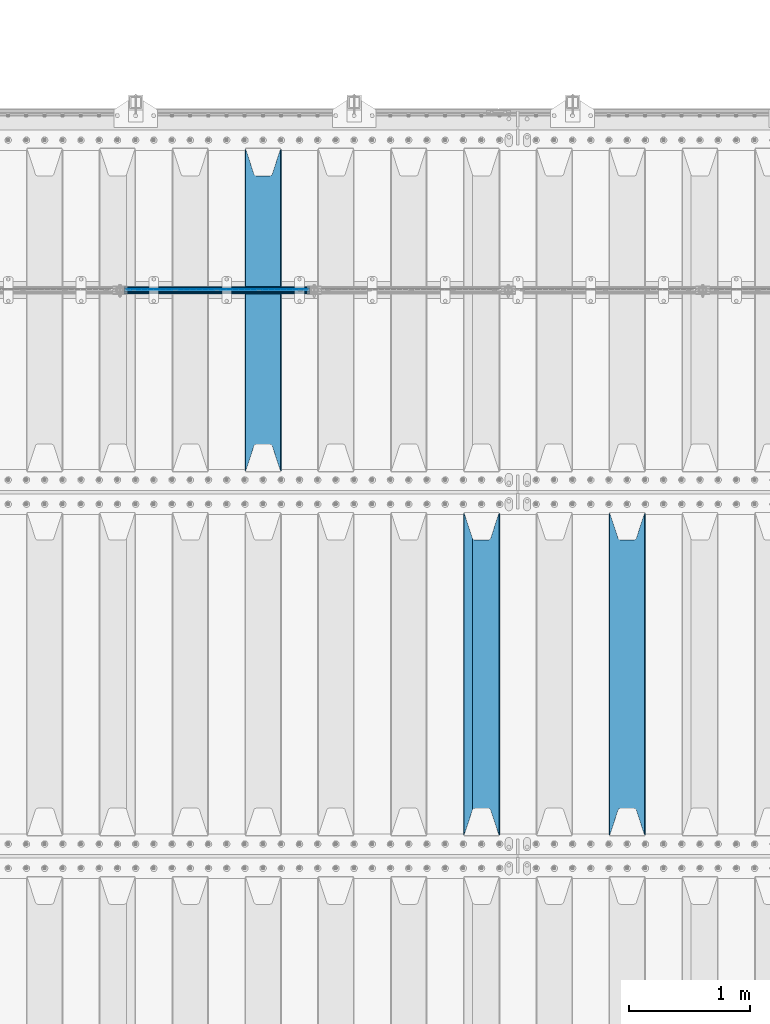
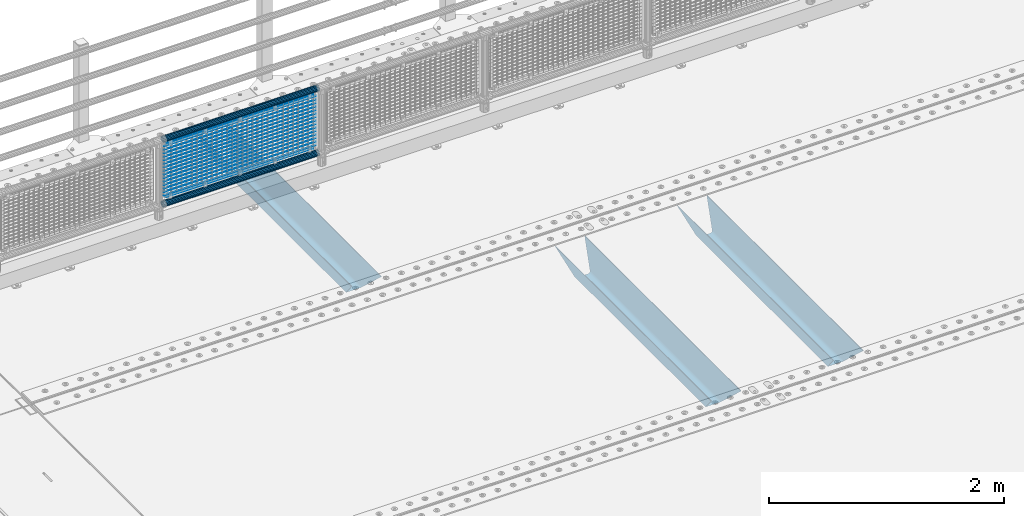
# One storey, part 117 of 257: 22 beams.
"""IFC2X3 building model written with IfcOpenShell, lengths in millimetres."""

from ifc_helpers import new_model, si_unit, frame, origin_with_axes, place, context, subcontext, project, spatial, faceted_brep, material, type_object, element, save


model = new_model("IFC2X3")

# Units and contexts
model_context = context("Model", 3, precision=1e-05, world=origin_with_axes())
body_context = subcontext(model_context, "Body", "Model", "MODEL_VIEW")
ifc_project = project(units=[si_unit("LENGTHUNIT", "METRE", prefix="MILLI"), si_unit("AREAUNIT", "SQUARE_METRE"), si_unit("VOLUMEUNIT", "CUBIC_METRE"), si_unit("MASSUNIT", "GRAM", prefix="KILO"), si_unit("TIMEUNIT", "SECOND"), si_unit("PLANEANGLEUNIT", "RADIAN"), si_unit("SOLIDANGLEUNIT", "STERADIAN"), si_unit("THERMODYNAMICTEMPERATUREUNIT", "DEGREE_CELSIUS"), si_unit("LUMINOUSINTENSITYUNIT", "LUMEN")], contexts=[model_context])

# Site, building, storey
site_placement = place(None, origin_with_axes())
site = spatial("IfcSite", under=ifc_project, at=site_placement, CompositionType="ELEMENT")
building_placement = place(site_placement, origin_with_axes())
building = spatial("IfcBuilding", under=site, at=building_placement, Name="Standard", CompositionType="ELEMENT")
storey_placement = place(building_placement, origin_with_axes())
storey = spatial("IfcBuildingStorey", under=building, at=storey_placement, Name="Undefined", CompositionType="ELEMENT", Elevation=0.0)

# Beams
ifc_material_1 = material(Name="STEEL/S355N")
beam_type_1 = type_object("IfcBeamType", PredefinedType="NOTDEFINED")
beam_1_placement = place(storey_placement, frame((48850.0, 6175.0, -115.0), z_axis=(0.0, 0.0, 1.0), x_axis=(0.0, 1.0, 0.0)))
element("IfcBeam", 1, at=beam_1_placement, inside=storey, type_object=beam_type_1, material=ifc_material_1, context=body_context, shape_type="Brep", body=[
    faceted_brep([(0.0, 150.0, 115.0), (0.0, 143.690000000002, 115.0), (2650.00000000297, 143.690000000002, 115.0), (2650.00000000297, 150.0, 115.0), (2650.00000000297, 142.059565218406, 110.0000000031), (2650.00000000297, 148.369565218403, 110.0000000031), (2441.90079219208, -80.1103600731149, -98.0992078077845), (2437.7588105432, -77.5672621345584, -102.241189456673), (2434.06523489746, -74.4080125315522, -105.934765102404), (2430.91086095089, -70.7102721255724, -109.089139048974), (2428.37322971128, -66.5649389910031, -111.626770288588), (2426.51472138055, -62.0739139532889, -113.485278619323), (2425.38102192091, -57.3475956567636, -114.618978078955), (2424.99999999987, -52.5021667386536, -115.0), (2424.99999999987, 52.5021667386536, -115.0), (2425.38102192091, 57.3475956567636, -114.618978078955), (2426.51472138055, 62.0739139532889, -113.485278619323), (2428.37322971128, 66.5649389910031, -111.626770288588), (2430.91086095089, 70.7102721255724, -109.089139048974), (2434.06523489746, 74.4080125315522, -105.934765102404), (2437.7588105432, 77.5672621345584, -102.241189456673), (2441.90079219208, 80.1103600731149, -98.0992078077846), (2446.38936140511, 81.9747917625791, -93.6106385947584), (2448.24948500409, 76.2713538057287, -91.7505149957729), (2444.62967112262, 74.76777986261, -95.3703288772456), (2441.28936334126, 72.7168944282894, -98.710636658607), (2438.31067330438, 70.1691124903809, -101.689326695487), (2435.76682334747, 67.1870637758839, -104.233176652398), (2433.72034654133, 63.8440531834931, -106.279653458539), (2432.22154950041, 60.2222587982324, -107.778450499454), (2431.30727574265, 56.4107117849126, -108.692724257221), (2430.99999999987, 52.5031078186876, -109.0), (2430.99999999987, -52.5031078186876, -109.0), (2431.30727574265, -56.4107117849126, -108.692724257221), (2432.22154950041, -60.2222587982324, -107.778450499454), (2433.72034654133, -63.8440531834931, -106.279653458539), (2435.76682334747, -67.1870637758839, -104.233176652398), (2438.31067330438, -70.1691124903809, -101.689326695487), (2441.28936334126, -72.7168944282894, -98.7106366586071), (2444.62967112262, -74.76777986261, -95.3703288772457), (2448.24948500409, -76.2713538057287, -91.7505149957729), (2650.00000000297, -142.059565218406, 110.0000000031), (2650.00000000297, -148.369565218403, 110.0000000031), (2446.38936140511, -81.9747917625791, -93.6106385947584), (2650.00000000297, -143.690000000002, 115.0), (2650.00000000297, -150.0, 115.0), (0.0, -143.690000000002, 115.0), (0.0, -150.0, 115.0), (0.0, -148.369565218258, 110.000000002662), (203.61063859742, -81.9747917625791, -93.6106385947584), (208.099207810447, -80.1103600731149, -98.0992078077845), (212.241189459335, -77.5672621345584, -102.241189456673), (215.934765105066, -74.4080125315522, -105.934765102404), (219.089139051636, -70.7102721255724, -109.089139048974), (221.626770291251, -66.5649389910031, -111.626770288588), (223.485278621985, -62.0739139532889, -113.485278619323), (224.618978081617, -57.3475956567636, -114.618978078955), (225.000000002662, -52.5021667386536, -115.0), (225.000000002662, 52.5021667386536, -115.0), (224.618978081617, 57.3475956567636, -114.618978078955), (223.485278621985, 62.0739139532889, -113.485278619323), (221.626770291251, 66.5649389910031, -111.626770288588), (219.089139051636, 70.7102721255724, -109.089139048974), (215.934765105066, 74.4080125315522, -105.934765102404), (212.241189459335, 77.5672621345584, -102.241189456673), (208.099207810447, 80.1103600731149, -98.0992078077846), (203.61063859742, 81.9747917625791, -93.6106385947584), (0.0, 148.369565218258, 110.000000002662), (0.0, 142.05956521826, 110.000000002662), (201.750514998435, 76.2713538057287, -91.7505149957729), (205.370328879908, 74.76777986261, -95.3703288772456), (208.710636661269, 72.7168944282894, -98.710636658607), (211.689326698149, 70.1691124903809, -101.689326695487), (214.233176655061, 67.1870637758839, -104.233176652398), (216.279653461201, 63.8440531834931, -106.279653458539), (217.778450502116, 60.2222587982324, -107.778450499454), (218.692724259884, 56.4107117849126, -108.692724257221), (219.000000002662, 52.5031078186876, -109.0), (219.000000002662, -52.5031078186876, -109.0), (218.692724259884, -56.4107117849126, -108.692724257221), (217.778450502116, -60.2222587982324, -107.778450499454), (216.279653461201, -63.8440531834931, -106.279653458539), (214.233176655061, -67.1870637758839, -104.233176652398), (211.689326698149, -70.1691124903809, -101.689326695487), (208.710636661269, -72.7168944282894, -98.7106366586071), (205.370328879908, -74.76777986261, -95.3703288772457), (201.750514998435, -76.2713538057287, -91.7505149957729), (0.0, -142.05956521826, 110.000000002662)], [[[0, 1, 2, 3]], [[3, 2, 4, 5]], [[6, 7, 8, 9, 10, 11, 12, 13, 14, 15, 16, 17, 18, 19, 20, 21, 22, 5, 4, 23, 24, 25, 26, 27, 28, 29, 30, 31, 32, 33, 34, 35, 36, 37, 38, 39, 40, 41, 42, 43]], [[44, 45, 42, 41]], [[46, 47, 45, 44]], [[43, 42, 45, 47, 48, 49]], [[6, 43, 49, 50]], [[7, 6, 50, 51]], [[8, 7, 51, 52]], [[9, 8, 52, 53]], [[10, 9, 53, 54]], [[11, 10, 54, 55]], [[12, 11, 55, 56]], [[13, 12, 56, 57]], [[14, 13, 57, 58]], [[15, 14, 58, 59]], [[16, 15, 59, 60]], [[17, 16, 60, 61]], [[18, 17, 61, 62]], [[19, 18, 62, 63]], [[20, 19, 63, 64]], [[21, 20, 64, 65]], [[22, 21, 65, 66]], [[0, 3, 5, 22, 66, 67]], [[1, 0, 67, 68]], [[23, 4, 2, 1, 68, 69]], [[24, 23, 69, 70]], [[25, 24, 70, 71]], [[26, 25, 71, 72]], [[27, 26, 72, 73]], [[28, 27, 73, 74]], [[29, 28, 74, 75]], [[30, 29, 75, 76]], [[31, 30, 76, 77]], [[32, 31, 77, 78]], [[33, 32, 78, 79]], [[34, 33, 79, 80]], [[35, 34, 80, 81]], [[36, 35, 81, 82]], [[37, 36, 82, 83]], [[38, 37, 83, 84]], [[39, 38, 84, 85]], [[40, 39, 85, 86]], [[46, 44, 41, 40, 86, 87]], [[47, 46, 87, 48]], [[86, 85, 84, 83, 82, 81, 80, 79, 78, 77, 76, 75, 74, 73, 72, 71, 70, 69, 68, 67, 66, 65, 64, 63, 62, 61, 60, 59, 58, 57, 56, 55, 54, 53, 52, 51, 50, 49, 48, 87]]]),
])
beam_2_placement = place(storey_placement, frame((47650.0, 6175.0, -115.0), z_axis=(0.0, 0.0, 1.0), x_axis=(0.0, 1.0, 0.0)))
element("IfcBeam", 2, at=beam_2_placement, inside=storey, type_object=beam_type_1, material=ifc_material_1, context=body_context, shape_type="Brep", body=[
    faceted_brep([(0.0, 150.0, 115.0), (0.0, 143.690000000002, 115.0), (2650.00000000297, 143.690000000002, 115.0), (2650.00000000297, 150.0, 115.0), (2650.00000000297, 142.059565218406, 110.0000000031), (2650.00000000297, 148.369565218403, 110.0000000031), (2441.90079219208, -80.1103600731149, -98.0992078077845), (2437.7588105432, -77.5672621345584, -102.241189456673), (2434.06523489746, -74.4080125315522, -105.934765102404), (2430.91086095089, -70.7102721255724, -109.089139048974), (2428.37322971128, -66.5649389910031, -111.626770288588), (2426.51472138055, -62.0739139532889, -113.485278619323), (2425.38102192091, -57.3475956567636, -114.618978078955), (2424.99999999987, -52.5021667386536, -115.0), (2424.99999999987, 52.5021667386536, -115.0), (2425.38102192091, 57.3475956567636, -114.618978078955), (2426.51472138055, 62.0739139532889, -113.485278619323), (2428.37322971128, 66.5649389910031, -111.626770288588), (2430.91086095089, 70.7102721255724, -109.089139048974), (2434.06523489746, 74.4080125315522, -105.934765102404), (2437.7588105432, 77.5672621345584, -102.241189456673), (2441.90079219208, 80.1103600731149, -98.0992078077846), (2446.38936140511, 81.9747917625791, -93.6106385947584), (2448.24948500409, 76.2713538057287, -91.7505149957729), (2444.62967112262, 74.76777986261, -95.3703288772456), (2441.28936334126, 72.7168944282894, -98.710636658607), (2438.31067330438, 70.1691124903809, -101.689326695487), (2435.76682334747, 67.1870637758839, -104.233176652398), (2433.72034654133, 63.8440531834931, -106.279653458539), (2432.22154950041, 60.2222587982324, -107.778450499454), (2431.30727574265, 56.4107117849126, -108.692724257221), (2430.99999999987, 52.5031078186876, -109.0), (2430.99999999987, -52.5031078186876, -109.0), (2431.30727574265, -56.4107117849126, -108.692724257221), (2432.22154950041, -60.2222587982324, -107.778450499454), (2433.72034654133, -63.8440531834931, -106.279653458539), (2435.76682334747, -67.1870637758839, -104.233176652398), (2438.31067330438, -70.1691124903809, -101.689326695487), (2441.28936334126, -72.7168944282894, -98.7106366586071), (2444.62967112262, -74.76777986261, -95.3703288772457), (2448.24948500409, -76.2713538057287, -91.7505149957729), (2650.00000000297, -142.059565218406, 110.0000000031), (2650.00000000297, -148.369565218403, 110.0000000031), (2446.38936140511, -81.9747917625791, -93.6106385947584), (2650.00000000297, -143.690000000002, 115.0), (2650.00000000297, -150.0, 115.0), (0.0, -143.690000000002, 115.0), (0.0, -150.0, 115.0), (0.0, -148.369565218258, 110.000000002662), (203.61063859742, -81.9747917625791, -93.6106385947584), (208.099207810447, -80.1103600731149, -98.0992078077845), (212.241189459335, -77.5672621345584, -102.241189456673), (215.934765105066, -74.4080125315522, -105.934765102404), (219.089139051636, -70.7102721255724, -109.089139048974), (221.626770291251, -66.5649389910031, -111.626770288588), (223.485278621985, -62.0739139532889, -113.485278619323), (224.618978081617, -57.3475956567636, -114.618978078955), (225.000000002662, -52.5021667386536, -115.0), (225.000000002662, 52.5021667386536, -115.0), (224.618978081617, 57.3475956567636, -114.618978078955), (223.485278621985, 62.0739139532889, -113.485278619323), (221.626770291251, 66.5649389910031, -111.626770288588), (219.089139051636, 70.7102721255724, -109.089139048974), (215.934765105066, 74.4080125315522, -105.934765102404), (212.241189459335, 77.5672621345584, -102.241189456673), (208.099207810447, 80.1103600731149, -98.0992078077846), (203.61063859742, 81.9747917625791, -93.6106385947584), (0.0, 148.369565218258, 110.000000002662), (0.0, 142.05956521826, 110.000000002662), (201.750514998435, 76.2713538057287, -91.7505149957729), (205.370328879908, 74.76777986261, -95.3703288772456), (208.710636661269, 72.7168944282894, -98.710636658607), (211.689326698149, 70.1691124903809, -101.689326695487), (214.233176655061, 67.1870637758839, -104.233176652398), (216.279653461201, 63.8440531834931, -106.279653458539), (217.778450502116, 60.2222587982324, -107.778450499454), (218.692724259884, 56.4107117849126, -108.692724257221), (219.000000002662, 52.5031078186876, -109.0), (219.000000002662, -52.5031078186876, -109.0), (218.692724259884, -56.4107117849126, -108.692724257221), (217.778450502116, -60.2222587982324, -107.778450499454), (216.279653461201, -63.8440531834931, -106.279653458539), (214.233176655061, -67.1870637758839, -104.233176652398), (211.689326698149, -70.1691124903809, -101.689326695487), (208.710636661269, -72.7168944282894, -98.7106366586071), (205.370328879908, -74.76777986261, -95.3703288772457), (201.750514998435, -76.2713538057287, -91.7505149957729), (0.0, -142.05956521826, 110.000000002662)], [[[0, 1, 2, 3]], [[3, 2, 4, 5]], [[6, 7, 8, 9, 10, 11, 12, 13, 14, 15, 16, 17, 18, 19, 20, 21, 22, 5, 4, 23, 24, 25, 26, 27, 28, 29, 30, 31, 32, 33, 34, 35, 36, 37, 38, 39, 40, 41, 42, 43]], [[44, 45, 42, 41]], [[46, 47, 45, 44]], [[43, 42, 45, 47, 48, 49]], [[6, 43, 49, 50]], [[7, 6, 50, 51]], [[8, 7, 51, 52]], [[9, 8, 52, 53]], [[10, 9, 53, 54]], [[11, 10, 54, 55]], [[12, 11, 55, 56]], [[13, 12, 56, 57]], [[14, 13, 57, 58]], [[15, 14, 58, 59]], [[16, 15, 59, 60]], [[17, 16, 60, 61]], [[18, 17, 61, 62]], [[19, 18, 62, 63]], [[20, 19, 63, 64]], [[21, 20, 64, 65]], [[22, 21, 65, 66]], [[0, 3, 5, 22, 66, 67]], [[1, 0, 67, 68]], [[23, 4, 2, 1, 68, 69]], [[24, 23, 69, 70]], [[25, 24, 70, 71]], [[26, 25, 71, 72]], [[27, 26, 72, 73]], [[28, 27, 73, 74]], [[29, 28, 74, 75]], [[30, 29, 75, 76]], [[31, 30, 76, 77]], [[32, 31, 77, 78]], [[33, 32, 78, 79]], [[34, 33, 79, 80]], [[35, 34, 80, 81]], [[36, 35, 81, 82]], [[37, 36, 82, 83]], [[38, 37, 83, 84]], [[39, 38, 84, 85]], [[40, 39, 85, 86]], [[46, 44, 41, 40, 86, 87]], [[47, 46, 87, 48]], [[86, 85, 84, 83, 82, 81, 80, 79, 78, 77, 76, 75, 74, 73, 72, 71, 70, 69, 68, 67, 66, 65, 64, 63, 62, 61, 60, 59, 58, 57, 56, 55, 54, 53, 52, 51, 50, 49, 48, 87]]]),
])
beam_3_placement = place(storey_placement, frame((45850.0, 9175.0, -115.0), z_axis=(0.0, 0.0, 1.0), x_axis=(0.0, 1.0, 0.0)))
element("IfcBeam", 3, at=beam_3_placement, inside=storey, type_object=beam_type_1, material=ifc_material_1, context=body_context, shape_type="Brep", body=[
    faceted_brep([(0.0, 150.0, 115.0), (0.0, 143.690000000002, 115.0), (2650.00000000297, 143.690000000002, 115.0), (2650.00000000297, 150.0, 115.0), (2650.00000000297, 142.059565218406, 110.0000000031), (2650.00000000297, 148.369565218403, 110.0000000031), (2441.90079219208, -80.1103600731149, -98.0992078077845), (2437.7588105432, -77.5672621345584, -102.241189456673), (2434.06523489746, -74.4080125315522, -105.934765102404), (2430.91086095089, -70.7102721255724, -109.089139048974), (2428.37322971128, -66.5649389910031, -111.626770288588), (2426.51472138055, -62.0739139532889, -113.485278619323), (2425.38102192091, -57.3475956567636, -114.618978078955), (2424.99999999987, -52.5021667386536, -115.0), (2424.99999999987, 52.5021667386536, -115.0), (2425.38102192091, 57.3475956567636, -114.618978078955), (2426.51472138055, 62.0739139532889, -113.485278619323), (2428.37322971128, 66.5649389910031, -111.626770288588), (2430.91086095089, 70.7102721255724, -109.089139048974), (2434.06523489746, 74.4080125315522, -105.934765102404), (2437.7588105432, 77.5672621345584, -102.241189456673), (2441.90079219208, 80.1103600731149, -98.0992078077846), (2446.38936140511, 81.9747917625791, -93.6106385947584), (2448.24948500409, 76.2713538057287, -91.7505149957729), (2444.62967112262, 74.76777986261, -95.3703288772456), (2441.28936334126, 72.7168944282894, -98.710636658607), (2438.31067330438, 70.1691124903809, -101.689326695487), (2435.76682334747, 67.1870637758839, -104.233176652398), (2433.72034654133, 63.8440531834931, -106.279653458539), (2432.22154950041, 60.2222587982324, -107.778450499454), (2431.30727574265, 56.4107117849126, -108.692724257221), (2430.99999999987, 52.5031078186876, -109.0), (2430.99999999987, -52.5031078186876, -109.0), (2431.30727574265, -56.4107117849126, -108.692724257221), (2432.22154950041, -60.2222587982324, -107.778450499454), (2433.72034654133, -63.8440531834931, -106.279653458539), (2435.76682334747, -67.1870637758839, -104.233176652398), (2438.31067330438, -70.1691124903809, -101.689326695487), (2441.28936334126, -72.7168944282894, -98.7106366586071), (2444.62967112262, -74.76777986261, -95.3703288772457), (2448.24948500409, -76.2713538057287, -91.7505149957729), (2650.00000000297, -142.059565218406, 110.0000000031), (2650.00000000297, -148.369565218403, 110.0000000031), (2446.38936140511, -81.9747917625791, -93.6106385947584), (2650.00000000297, -143.690000000002, 115.0), (2650.00000000297, -150.0, 115.0), (0.0, -143.690000000002, 115.0), (0.0, -150.0, 115.0), (0.0, -148.369565218258, 110.000000002662), (203.61063859742, -81.9747917625791, -93.6106385947584), (208.099207810447, -80.1103600731149, -98.0992078077845), (212.241189459335, -77.5672621345584, -102.241189456673), (215.934765105066, -74.4080125315522, -105.934765102404), (219.089139051636, -70.7102721255724, -109.089139048974), (221.626770291251, -66.5649389910031, -111.626770288588), (223.485278621985, -62.0739139532889, -113.485278619323), (224.618978081617, -57.3475956567636, -114.618978078955), (225.000000002662, -52.5021667386536, -115.0), (225.000000002662, 52.5021667386536, -115.0), (224.618978081617, 57.3475956567636, -114.618978078955), (223.485278621985, 62.0739139532889, -113.485278619323), (221.626770291251, 66.5649389910031, -111.626770288588), (219.089139051636, 70.7102721255724, -109.089139048974), (215.934765105066, 74.4080125315522, -105.934765102404), (212.241189459335, 77.5672621345584, -102.241189456673), (208.099207810447, 80.1103600731149, -98.0992078077846), (203.61063859742, 81.9747917625791, -93.6106385947584), (0.0, 148.369565218258, 110.000000002662), (0.0, 142.05956521826, 110.000000002662), (201.750514998435, 76.2713538057287, -91.7505149957729), (205.370328879908, 74.76777986261, -95.3703288772456), (208.710636661269, 72.7168944282894, -98.710636658607), (211.689326698149, 70.1691124903809, -101.689326695487), (214.233176655061, 67.1870637758839, -104.233176652398), (216.279653461201, 63.8440531834931, -106.279653458539), (217.778450502116, 60.2222587982324, -107.778450499454), (218.692724259884, 56.4107117849126, -108.692724257221), (219.000000002662, 52.5031078186876, -109.0), (219.000000002662, -52.5031078186876, -109.0), (218.692724259884, -56.4107117849126, -108.692724257221), (217.778450502116, -60.2222587982324, -107.778450499454), (216.279653461201, -63.8440531834931, -106.279653458539), (214.233176655061, -67.1870637758839, -104.233176652398), (211.689326698149, -70.1691124903809, -101.689326695487), (208.710636661269, -72.7168944282894, -98.7106366586071), (205.370328879908, -74.76777986261, -95.3703288772457), (201.750514998435, -76.2713538057287, -91.7505149957729), (0.0, -142.05956521826, 110.000000002662)], [[[0, 1, 2, 3]], [[3, 2, 4, 5]], [[6, 7, 8, 9, 10, 11, 12, 13, 14, 15, 16, 17, 18, 19, 20, 21, 22, 5, 4, 23, 24, 25, 26, 27, 28, 29, 30, 31, 32, 33, 34, 35, 36, 37, 38, 39, 40, 41, 42, 43]], [[44, 45, 42, 41]], [[46, 47, 45, 44]], [[43, 42, 45, 47, 48, 49]], [[6, 43, 49, 50]], [[7, 6, 50, 51]], [[8, 7, 51, 52]], [[9, 8, 52, 53]], [[10, 9, 53, 54]], [[11, 10, 54, 55]], [[12, 11, 55, 56]], [[13, 12, 56, 57]], [[14, 13, 57, 58]], [[15, 14, 58, 59]], [[16, 15, 59, 60]], [[17, 16, 60, 61]], [[18, 17, 61, 62]], [[19, 18, 62, 63]], [[20, 19, 63, 64]], [[21, 20, 64, 65]], [[22, 21, 65, 66]], [[0, 3, 5, 22, 66, 67]], [[1, 0, 67, 68]], [[23, 4, 2, 1, 68, 69]], [[24, 23, 69, 70]], [[25, 24, 70, 71]], [[26, 25, 71, 72]], [[27, 26, 72, 73]], [[28, 27, 73, 74]], [[29, 28, 74, 75]], [[30, 29, 75, 76]], [[31, 30, 76, 77]], [[32, 31, 77, 78]], [[33, 32, 78, 79]], [[34, 33, 79, 80]], [[35, 34, 80, 81]], [[36, 35, 81, 82]], [[37, 36, 82, 83]], [[38, 37, 83, 84]], [[39, 38, 84, 85]], [[40, 39, 85, 86]], [[46, 44, 41, 40, 86, 87]], [[47, 46, 87, 48]], [[86, 85, 84, 83, 82, 81, 80, 79, 78, 77, 76, 75, 74, 73, 72, 71, 70, 69, 68, 67, 66, 65, 64, 63, 62, 61, 60, 59, 58, 57, 56, 55, 54, 53, 52, 51, 50, 49, 48, 87]]]),
])
ifc_material_2 = material(Name="Misc_Undefined")
beam_type_2 = type_object("IfcBeamType", Name="D3", PredefinedType="NOTDEFINED")
for number, where, z_axis, x_axis in (
    (4, (44726.0, 10670.5, 851.596999999999), (0.0, 0.0, 1.0), (1.0, 0.0, 0.0)),
    (5, (44726.0, 10670.5, 669.452), (0.0, 0.0, 1.0), (1.0, 0.0, 0.0)),
    (6, (44726.0, 10670.5, 523.736), (0.0, 0.0, 1.0), (1.0, 0.0, 0.0)),
    (7, (44726.0, 10670.5, 487.307), (0.0, 0.0, 1.0), (1.0, 0.0, 0.0)),
    (8, (44726.0, 10670.5, 705.881), (0.0, 0.0, 1.0), (1.0, 0.0, 0.0)),
    (9, (44726.0, 10670.5, 596.594), (0.0, 0.0, 1.0), (1.0, 0.0, 0.0)),
    (10, (44726.0, 10670.5, 450.878), (0.0, 0.0, 1.0), (1.0, 0.0, 0.0)),
    (11, (44726.0, 10670.5, 815.167999999999), (0.0, 0.0, 1.0), (1.0, 0.0, 0.0)),
    (12, (44726.0, 10670.5, 888.025999999999), (0.0, 0.0, 1.0), (1.0, 0.0, 0.0)),
    (13, (44726.0, 10670.5, 778.738999999999), (0.0, 0.0, 1.0), (1.0, 0.0, 0.0)),
    (14, (44726.0, 10670.5, 742.309999999999), (0.0, 0.0, 1.0), (1.0, 0.0, 0.0)),
    (15, (44726.0, 10670.5, 633.023), (0.0, 0.0, 1.0), (1.0, 0.0, 0.0)),
    (16, (44726.0, 10670.5, 560.165), (0.0, 0.0, 1.0), (1.0, 0.0, 0.0)),
    (17, (44726.0, 10670.5, 414.449), (0.0, 0.0, 1.0), (1.0, 0.0, 0.0)),
):
    element("IfcBeam", number, at=place(storey_placement, frame(where, z_axis=z_axis, x_axis=x_axis)), inside=storey, type_object=beam_type_2, material=ifc_material_2, ObjectType="D3", context=body_context, shape_type="Brep", body=[
        faceted_brep([(0.0, -1.5, -5.6843418860808e-14), (0.0, -0.750000000001819, -1.29903810567669), (1490.0, -0.75, -1.29903810567669), (1490.0, -1.5, 0.0), (7.27595761418343e-12, 0.749999999998181, -1.29903810567669), (1490.0, 0.75, -1.29903810567669), (0.0, 1.5, -5.6843418860808e-14), (1490.0, 1.5, 0.0), (7.27595761418343e-12, 0.749999999998181, 1.29903810567669), (1490.0, 0.75, 1.29903810567669), (0.0, -0.750000000001819, 1.29903810567669), (1490.0, -0.75, 1.29903810567669)], [[[0, 1, 2, 3]], [[1, 4, 5, 2]], [[4, 6, 7, 5]], [[6, 8, 9, 7]], [[8, 10, 11, 9]], [[10, 0, 3, 11]], [[5, 7, 9, 11, 3, 2]], [[10, 8, 6, 4, 1, 0]]]),
    ])
beam_4_placement = place(storey_placement, frame((44751.0, 10670.5, 353.02), z_axis=(0.0, 0.0, 1.0), x_axis=(1.0, 0.0, 0.0)))
element("IfcBeam", 18, at=beam_4_placement, inside=storey, type_object=beam_type_2, material=ifc_material_2, ObjectType="D3", context=body_context, shape_type="Brep", body=[
    faceted_brep([(0.0, -1.5, -5.6843418860808e-14), (0.0, -0.750000000001819, -1.29903810567669), (1440.0, -0.75, -1.29903810567669), (1440.0, -1.5, 0.0), (7.27595761418343e-12, 0.749999999998181, -1.29903810567669), (1440.0, 0.75, -1.29903810567663), (0.0, 1.5, -5.6843418860808e-14), (1440.0, 1.5, 0.0), (7.27595761418343e-12, 0.749999999998181, 1.29903810567669), (1440.0, 0.75, 1.29903810567669), (0.0, -0.750000000001819, 1.29903810567669), (1440.0, -0.75, 1.29903810567669)], [[[0, 1, 2, 3]], [[1, 4, 5, 2]], [[4, 6, 7, 5]], [[6, 8, 9, 7]], [[8, 10, 11, 9]], [[10, 0, 3, 11]], [[5, 7, 9, 11, 3, 2]], [[10, 8, 6, 4, 1, 0]]]),
])
beam_5_placement = place(storey_placement, frame((44726.0, 10670.5, 378.02), z_axis=(0.0, 0.0, 1.0), x_axis=(1.0, 0.0, 0.0)))
element("IfcBeam", 19, at=beam_5_placement, inside=storey, type_object=beam_type_2, material=ifc_material_2, ObjectType="D3", context=body_context, shape_type="Brep", body=[
    faceted_brep([(0.0, -1.5, -5.6843418860808e-14), (0.0, -0.750000000001819, -1.29903810567669), (1490.0, -0.75, -1.29903810567669), (1490.0, -1.5, 0.0), (7.27595761418343e-12, 0.749999999998181, -1.29903810567669), (1490.0, 0.75, -1.29903810567669), (0.0, 1.5, -5.6843418860808e-14), (1490.0, 1.5, 0.0), (7.27595761418343e-12, 0.749999999998181, 1.29903810567669), (1490.0, 0.75, 1.29903810567669), (0.0, -0.750000000001819, 1.29903810567669), (1490.0, -0.75, 1.29903810567669)], [[[0, 1, 2, 3]], [[1, 4, 5, 2]], [[4, 6, 7, 5]], [[6, 8, 9, 7]], [[8, 10, 11, 9]], [[10, 0, 3, 11]], [[5, 7, 9, 11, 3, 2]], [[10, 8, 6, 4, 1, 0]]]),
])
beam_6_placement = place(storey_placement, frame((44751.0, 10670.5, 913.02), z_axis=(0.0, 0.0, 1.0), x_axis=(1.0, 0.0, 0.0)))
element("IfcBeam", 20, at=beam_6_placement, inside=storey, type_object=beam_type_2, material=ifc_material_2, ObjectType="D3", context=body_context, shape_type="Brep", body=[
    faceted_brep([(0.0, -1.5, -5.6843418860808e-14), (0.0, -0.750000000001819, -1.29903810567669), (1440.0, -0.75, -1.29903810567669), (1440.0, -1.5, 0.0), (7.27595761418343e-12, 0.749999999998181, -1.29903810567669), (1440.0, 0.75, -1.29903810567663), (0.0, 1.5, -5.6843418860808e-14), (1440.0, 1.5, 0.0), (7.27595761418343e-12, 0.749999999998181, 1.29903810567669), (1440.0, 0.75, 1.29903810567669), (0.0, -0.750000000001819, 1.29903810567669), (1440.0, -0.75, 1.29903810567669)], [[[0, 1, 2, 3]], [[1, 4, 5, 2]], [[4, 6, 7, 5]], [[6, 8, 9, 7]], [[8, 10, 11, 9]], [[10, 0, 3, 11]], [[5, 7, 9, 11, 3, 2]], [[10, 8, 6, 4, 1, 0]]]),
])
ifc_material_3 = material()
beam_type_3 = type_object("IfcBeamType", PredefinedType="NOTDEFINED")
beam_7_placement = place(storey_placement, frame((44705.85, 10664.5, 298.170000000001), z_axis=(0.0, 0.0, 1.0), x_axis=(1.0, 0.0, 0.0)))
element("IfcBeam", 21, at=beam_7_placement, inside=storey, type_object=beam_type_3, material=ifc_material_3, context=body_context, shape_type="Brep", body=[
    faceted_brep([(0.0, -25.3500000000004, 0.0), (0.0, -23.4203461491616, 9.70102501045767), (1530.0, -23.4203461491616, 9.70102501045506), (1530.0, -25.3500000000004, 0.0), (0.0, -17.9251569030785, 17.9251569030821), (1530.0, -17.9251569030785, 17.925156903079), (0.0, -9.70102501045585, 23.4203461491634), (1530.0, -9.70102501045585, 23.4203461491611), (0.0, 0.0, 25.3499999999985), (1530.0, 0.0, 25.35), (0.0, 9.70102501045585, 23.4203461491634), (1530.0, 9.70102501045585, 23.4203461491611), (0.0, 17.9251569030785, 17.9251569030821), (1530.0, 17.9251569030785, 17.925156903079), (0.0, 23.4203461491616, 9.70102501045767), (1530.0, 23.4203461491616, 9.701025010455), (0.0, 25.3500000000004, 0.0), (1530.0, 25.3500000000004, 0.0), (0.0, 23.4203461491616, -9.70102501045767), (1530.0, 23.4203461491616, -9.70102501045506), (0.0, 17.9251569030785, -17.9251569030821), (1530.0, 17.9251569030785, -17.925156903079), (0.0, 9.70102501045585, -23.4203461491634), (1530.0, 9.70102501045585, -23.4203461491611), (0.0, 0.0, -25.3499999999985), (1530.0, 0.0, -25.35), (0.0, -9.70102501045585, -23.4203461491634), (1530.0, -9.70102501045585, -23.4203461491611), (0.0, -17.9251569030785, -17.9251569030821), (1530.0, -17.9251569030785, -17.925156903079), (0.0, -23.4203461491616, -9.70102501045767), (1530.0, -23.4203461491616, -9.701025010455), (0.0, -30.1499999999996, 0.0), (0.0, -27.8549679052157, -11.5379054858058), (1530.0, -27.8549679052157, -11.5379054858075), (1530.0, -30.1499999999996, 0.0), (0.0, -21.3192694527752, -21.3192694527752), (1530.0, -21.3192694527752, -21.3192694527744), (0.0, -11.5379054858076, -27.8549679052157), (1530.0, -11.5379054858076, -27.8549679052153), (0.0, 0.0, -30.1500000000015), (1530.0, 0.0, -30.15), (0.0, 11.5379054858076, -27.8549679052157), (1530.0, 11.5379054858076, -27.8549679052153), (0.0, 21.3192694527752, -21.3192694527752), (1530.0, 21.3192694527752, -21.3192694527744), (0.0, 27.8549679052157, -11.5379054858058), (1530.0, 27.8549679052157, -11.5379054858075), (0.0, 30.1499999999996, 0.0), (1530.0, 30.1499999999996, 0.0), (0.0, 27.8549679052157, 11.5379054858058), (1530.0, 27.8549679052157, 11.5379054858075), (0.0, 21.3192694527752, 21.3192694527752), (1530.0, 21.3192694527752, 21.3192694527744), (0.0, 11.5379054858076, 27.8549679052157), (1530.0, 11.5379054858076, 27.8549679052153), (0.0, 0.0, 30.1500000000015), (1530.0, 0.0, 30.15), (0.0, -11.5379054858076, 27.8549679052157), (1530.0, -11.5379054858076, 27.8549679052153), (0.0, -21.3192694527752, 21.3192694527752), (1530.0, -21.3192694527752, 21.3192694527744), (0.0, -27.8549679052157, 11.5379054858058), (1530.0, -27.8549679052157, 11.5379054858075)], [[[0, 1, 2, 3]], [[1, 4, 5, 2]], [[4, 6, 7, 5]], [[6, 8, 9, 7]], [[8, 10, 11, 9]], [[10, 12, 13, 11]], [[12, 14, 15, 13]], [[14, 16, 17, 15]], [[16, 18, 19, 17]], [[18, 20, 21, 19]], [[20, 22, 23, 21]], [[22, 24, 25, 23]], [[24, 26, 27, 25]], [[26, 28, 29, 27]], [[28, 30, 31, 29]], [[30, 0, 3, 31]], [[32, 33, 34, 35]], [[33, 36, 37, 34]], [[36, 38, 39, 37]], [[38, 40, 41, 39]], [[40, 42, 43, 41]], [[42, 44, 45, 43]], [[44, 46, 47, 45]], [[46, 48, 49, 47]], [[48, 50, 51, 49]], [[50, 52, 53, 51]], [[52, 54, 55, 53]], [[54, 56, 57, 55]], [[56, 58, 59, 57]], [[58, 60, 61, 59]], [[60, 62, 63, 61]], [[62, 32, 35, 63]], [[37, 39, 41, 43, 45, 47, 49, 51, 53, 55, 57, 59, 61, 63, 35, 34], [5, 7, 9, 11, 13, 15, 17, 19, 21, 23, 25, 27, 29, 31, 3, 2]], [[62, 60, 58, 56, 54, 52, 50, 48, 46, 44, 42, 40, 38, 36, 33, 32], [30, 28, 26, 24, 22, 20, 18, 16, 14, 12, 10, 8, 6, 4, 1, 0]]]),
])
beam_8_placement = place(storey_placement, frame((44705.85, 10664.5, 969.849999999999), z_axis=(0.0, 0.0, 1.0), x_axis=(1.0, 0.0, 0.0)))
element("IfcBeam", 22, at=beam_8_placement, inside=storey, type_object=beam_type_3, material=ifc_material_3, context=body_context, shape_type="Brep", body=[
    faceted_brep([(0.0, -25.3500000000004, 0.0), (0.0, -23.4203461491616, 9.70102501045767), (1530.0, -23.4203461491616, 9.70102501045506), (1530.0, -25.3500000000004, 0.0), (0.0, -17.9251569030785, 17.9251569030821), (1530.0, -17.9251569030785, 17.925156903079), (0.0, -9.70102501045585, 23.4203461491634), (1530.0, -9.70102501045585, 23.4203461491611), (0.0, 0.0, 25.3499999999985), (1530.0, 0.0, 25.35), (0.0, 9.70102501045585, 23.4203461491634), (1530.0, 9.70102501045585, 23.4203461491611), (0.0, 17.9251569030785, 17.9251569030821), (1530.0, 17.9251569030785, 17.925156903079), (0.0, 23.4203461491616, 9.70102501045767), (1530.0, 23.4203461491616, 9.701025010455), (0.0, 25.3500000000004, 0.0), (1530.0, 25.3500000000004, 0.0), (0.0, 23.4203461491616, -9.70102501045767), (1530.0, 23.4203461491616, -9.70102501045506), (0.0, 17.9251569030785, -17.9251569030821), (1530.0, 17.9251569030785, -17.925156903079), (0.0, 9.70102501045585, -23.4203461491634), (1530.0, 9.70102501045585, -23.4203461491611), (0.0, 0.0, -25.3499999999985), (1530.0, 0.0, -25.35), (0.0, -9.70102501045585, -23.4203461491634), (1530.0, -9.70102501045585, -23.4203461491611), (0.0, -17.9251569030785, -17.9251569030821), (1530.0, -17.9251569030785, -17.925156903079), (0.0, -23.4203461491616, -9.70102501045767), (1530.0, -23.4203461491616, -9.701025010455), (0.0, -30.1499999999996, 0.0), (0.0, -27.8549679052157, -11.5379054858058), (1530.0, -27.8549679052157, -11.5379054858075), (1530.0, -30.1499999999996, 0.0), (0.0, -21.3192694527752, -21.3192694527752), (1530.0, -21.3192694527752, -21.3192694527744), (0.0, -11.5379054858076, -27.8549679052157), (1530.0, -11.5379054858076, -27.8549679052153), (0.0, 0.0, -30.1500000000015), (1530.0, 0.0, -30.15), (0.0, 11.5379054858076, -27.8549679052157), (1530.0, 11.5379054858076, -27.8549679052153), (0.0, 21.3192694527752, -21.3192694527752), (1530.0, 21.3192694527752, -21.3192694527744), (0.0, 27.8549679052157, -11.5379054858058), (1530.0, 27.8549679052157, -11.5379054858075), (0.0, 30.1499999999996, 0.0), (1530.0, 30.1499999999996, 0.0), (0.0, 27.8549679052157, 11.5379054858058), (1530.0, 27.8549679052157, 11.5379054858075), (0.0, 21.3192694527752, 21.3192694527752), (1530.0, 21.3192694527752, 21.3192694527744), (0.0, 11.5379054858076, 27.8549679052157), (1530.0, 11.5379054858076, 27.8549679052153), (0.0, 0.0, 30.1500000000015), (1530.0, 0.0, 30.15), (0.0, -11.5379054858076, 27.8549679052157), (1530.0, -11.5379054858076, 27.8549679052153), (0.0, -21.3192694527752, 21.3192694527752), (1530.0, -21.3192694527752, 21.3192694527744), (0.0, -27.8549679052157, 11.5379054858058), (1530.0, -27.8549679052157, 11.5379054858075)], [[[0, 1, 2, 3]], [[1, 4, 5, 2]], [[4, 6, 7, 5]], [[6, 8, 9, 7]], [[8, 10, 11, 9]], [[10, 12, 13, 11]], [[12, 14, 15, 13]], [[14, 16, 17, 15]], [[16, 18, 19, 17]], [[18, 20, 21, 19]], [[20, 22, 23, 21]], [[22, 24, 25, 23]], [[24, 26, 27, 25]], [[26, 28, 29, 27]], [[28, 30, 31, 29]], [[30, 0, 3, 31]], [[32, 33, 34, 35]], [[33, 36, 37, 34]], [[36, 38, 39, 37]], [[38, 40, 41, 39]], [[40, 42, 43, 41]], [[42, 44, 45, 43]], [[44, 46, 47, 45]], [[46, 48, 49, 47]], [[48, 50, 51, 49]], [[50, 52, 53, 51]], [[52, 54, 55, 53]], [[54, 56, 57, 55]], [[56, 58, 59, 57]], [[58, 60, 61, 59]], [[60, 62, 63, 61]], [[62, 32, 35, 63]], [[37, 39, 41, 43, 45, 47, 49, 51, 53, 55, 57, 59, 61, 63, 35, 34], [5, 7, 9, 11, 13, 15, 17, 19, 21, 23, 25, 27, 29, 31, 3, 2]], [[62, 60, 58, 56, 54, 52, 50, 48, 46, 44, 42, 40, 38, 36, 33, 32], [30, 28, 26, 24, 22, 20, 18, 16, 14, 12, 10, 8, 6, 4, 1, 0]]]),
])

save(model, "model.ifc")
